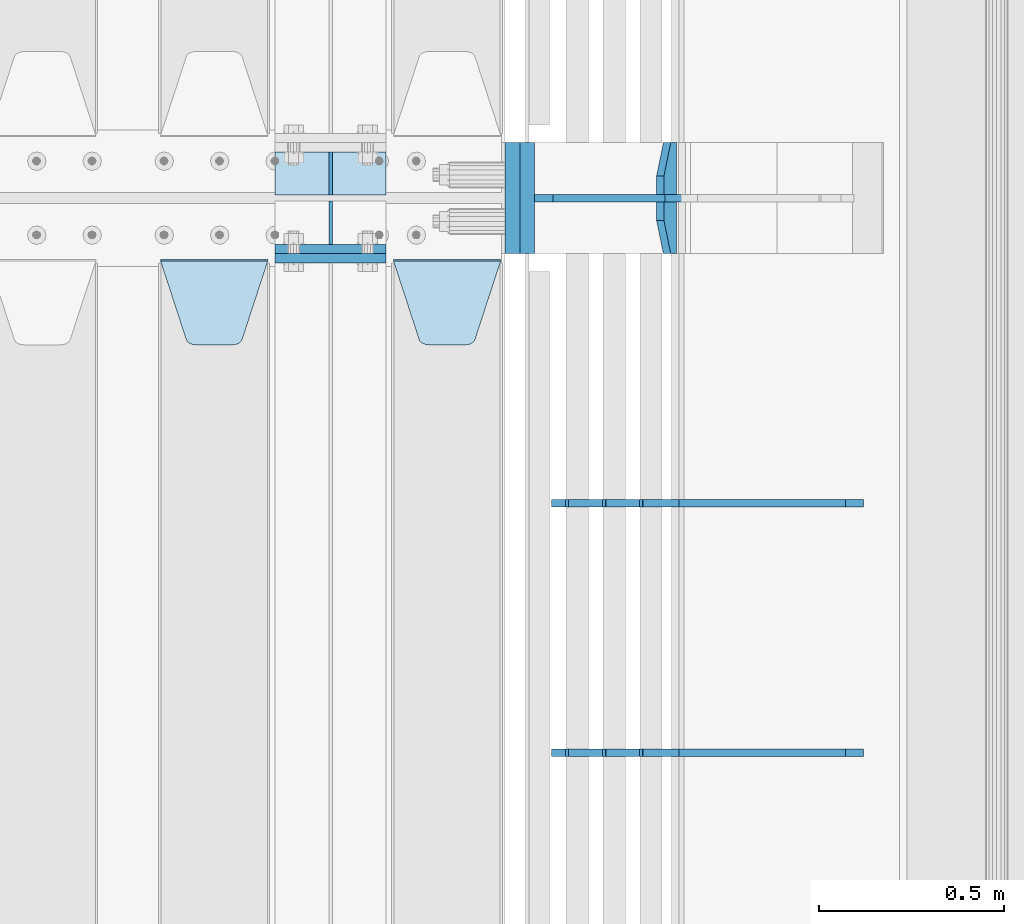
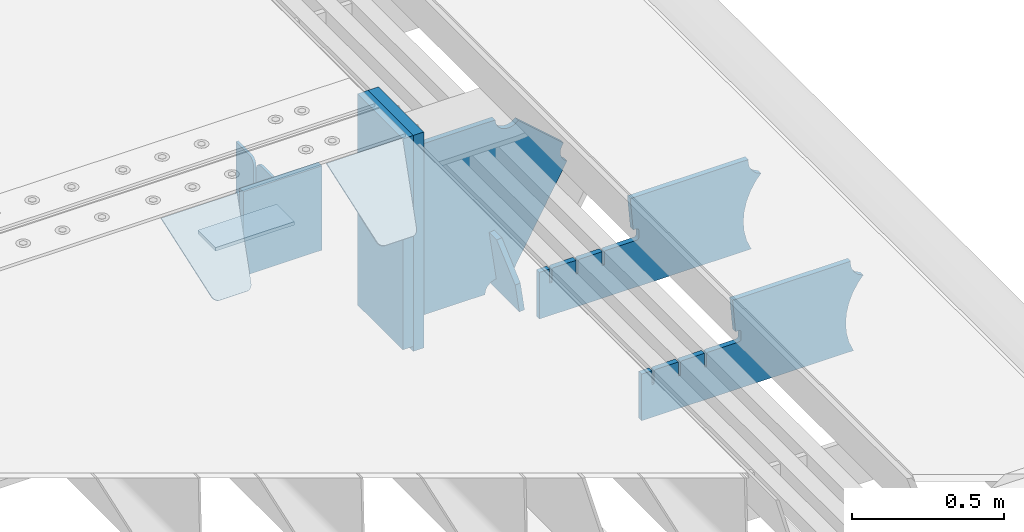
# One storey, part 190 of 208: 13 plates.
"""IFC2X3 building model written with IfcOpenShell, lengths in millimetres."""

from ifc_helpers import new_model, si_unit, frame, origin_with_axes, place, context, subcontext, project, spatial, faceted_brep, material, type_object, element, save


model = new_model("IFC2X3")

# Units and contexts
model_context = context("Model", 3, precision=1e-05, world=origin_with_axes())
body_context = subcontext(model_context, "Body", "Model", "MODEL_VIEW")
ifc_project = project(units=[si_unit("LENGTHUNIT", "METRE", prefix="MILLI"), si_unit("AREAUNIT", "SQUARE_METRE"), si_unit("VOLUMEUNIT", "CUBIC_METRE"), si_unit("MASSUNIT", "GRAM", prefix="KILO"), si_unit("TIMEUNIT", "SECOND"), si_unit("PLANEANGLEUNIT", "RADIAN"), si_unit("SOLIDANGLEUNIT", "STERADIAN"), si_unit("THERMODYNAMICTEMPERATUREUNIT", "DEGREE_CELSIUS"), si_unit("LUMINOUSINTENSITYUNIT", "LUMEN")], contexts=[model_context])

# Site, building, storey
site_placement = place(None, origin_with_axes())
site = spatial("IfcSite", under=ifc_project, at=site_placement, CompositionType="ELEMENT")
building_placement = place(site_placement, origin_with_axes())
building = spatial("IfcBuilding", under=site, at=building_placement, Name="Standard", CompositionType="ELEMENT")
storey_placement = place(building_placement, origin_with_axes())
storey = spatial("IfcBuildingStorey", under=building, at=storey_placement, Name="Undefined", CompositionType="ELEMENT", Elevation=0.0)

# Plates
ifc_material_1 = material(Name="STEEL/S355N")
plate_type_1 = type_object("IfcPlateType", PredefinedType="NOTDEFINED")
plate_1_placement = place(storey_placement, frame((-26255.0, 2862.49999999999, -339.999999999993), z_axis=(0.0, 0.0, 1.0), x_axis=(1.0, 0.0, 0.0)))
element("IfcPlate", 1, at=plate_1_placement, inside=storey, type_object=plate_type_1, material=ifc_material_1, context=body_context, shape_type="Brep", body=[
    faceted_brep([(0.0, -12.5, 0.0), (0.0, -12.5, 310.0), (0.0, 12.5, 310.0), (0.0, 12.5, 0.0), (300.0, -12.5, 310.0), (300.0, 12.5, 310.0), (300.0, -12.5, 0.0), (300.0, 12.5, 0.0)], [[[0, 1, 2, 3]], [[1, 4, 5, 2]], [[4, 6, 7, 5]], [[6, 0, 3, 7]], [[5, 7, 3, 2]], [[6, 4, 1, 0]]]),
])
plate_2_placement = place(storey_placement, frame((-26255.0, 2837.5, -340.000000000044), z_axis=(0.0, 0.0, 1.0), x_axis=(1.0, 0.0, 0.0)))
element("IfcPlate", 2, at=plate_2_placement, inside=storey, type_object=plate_type_1, material=ifc_material_1, context=body_context, shape_type="Brep", body=[
    faceted_brep([(0.0, -12.5, 0.0), (0.0, -12.5, 340.0), (0.0, 12.5, 340.0), (0.0, 12.5, 0.0), (300.0, -12.5, 340.0), (300.0, 12.5, 340.0), (300.0, -12.5, 0.0), (300.0, 12.5, 0.0)], [[[0, 1, 2, 3]], [[1, 4, 5, 2]], [[4, 6, 7, 5]], [[6, 0, 3, 7]], [[5, 7, 3, 2]], [[6, 4, 1, 0]]]),
])
plate_type_2 = type_object("IfcPlateType", PredefinedType="NOTDEFINED")
plate_3_placement = place(storey_placement, frame((-26255.0, 3007.99999999999, -342.999999999993), z_axis=(0.0, 1.0, 0.0), x_axis=(1.0, 0.0, 0.0)))
element("IfcPlate", 3, at=plate_3_placement, inside=storey, type_object=plate_type_2, material=ifc_material_1, context=body_context, shape_type="Brep", body=[
    faceted_brep([(0.0, -7.0, 0.0), (0.0, -7.0, 117.0), (0.0, 7.0, 117.0), (0.0, 7.0, 0.0), (300.0, -7.0, 117.0), (300.0, 7.0, 117.0), (300.0, -7.0, 0.0), (300.0, 7.0, 0.0)], [[[0, 1, 2, 3]], [[1, 4, 5, 2]], [[4, 6, 7, 5]], [[6, 0, 3, 7]], [[5, 7, 3, 2]], [[6, 4, 1, 0]]]),
])
plate_type_3 = type_object("IfcPlateType", PredefinedType="NOTDEFINED")
for number, where, z_axis, x_axis in (
    (4, (-26105.0, 3007.99999999999, -29.999999999993), (0.0, 0.0, -1.0), (0.0, 1.0, 0.0)),
    (5, (-26105.0, 2991.99999999999, -29.999999999993), (0.0, 0.0, -1.0), (0.0, -1.0, 0.0)),
):
    element("IfcPlate", number, at=place(storey_placement, frame(where, z_axis=z_axis, x_axis=x_axis)), inside=storey, type_object=plate_type_3, material=ifc_material_1, context=body_context, shape_type="Brep", body=[
        faceted_brep([(0.0, -5.0, 30.0), (0.0, -5.0, 306.0), (0.0, 5.0, 306.0), (0.0, 5.0, 30.0), (117.0, -5.0, 306.0), (117.0, 5.0, 306.0), (117.0, -5.0, 0.0), (117.0, 5.0, 0.0), (30.0, -5.0, 0.0), (30.0, 5.0, 0.0), (24.7905546699922, -5.0, 0.455767409633758), (24.7905546699922, 5.0, 0.455767409633758), (19.7393957002296, -5.0, 1.80922137642275), (19.7393957002296, 5.0, 1.80922137642275), (15.0, -5.0, 4.01923788646684), (15.0, 5.0, 4.01923788646684), (10.7163717094036, -5.0, 7.01866670643066), (10.7163717094036, 5.0, 7.01866670643066), (7.01866670643085, -5.0, 10.7163717094038), (7.01866670643085, 5.0, 10.7163717094038), (4.01923788646673, -5.0, 15.0), (4.01923788646673, 5.0, 15.0), (1.80922137642301, -5.0, 19.7393957002299), (1.80922137642301, 5.0, 19.7393957002299), (0.455767409634063, -5.0, 24.7905546699921), (0.455767409634063, 5.0, 24.7905546699921)], [[[0, 1, 2, 3]], [[1, 4, 5, 2]], [[4, 6, 7, 5]], [[6, 8, 9, 7]], [[8, 10, 11, 9]], [[10, 12, 13, 11]], [[12, 14, 15, 13]], [[14, 16, 17, 15]], [[16, 18, 19, 17]], [[18, 20, 21, 19]], [[20, 22, 23, 21]], [[22, 24, 25, 23]], [[24, 0, 3, 25]], [[5, 7, 9, 11, 13, 15, 17, 19, 21, 23, 25, 3, 2]], [[24, 22, 20, 18, 16, 14, 12, 10, 8, 6, 4, 1, 0]]]),
    ])
plate_type_4 = type_object("IfcPlateType", PredefinedType="NOTDEFINED")
plate_4_placement = place(storey_placement, frame((-25935.0, 2831.76776695596, -1.76776695296758), z_axis=(0.0, -0.707106781186548, -0.707106781186547), x_axis=(1.0, 0.0, 0.0)))
element("IfcPlate", 6, at=plate_4_placement, inside=storey, type_object=plate_type_4, material=ifc_material_1, context=body_context, shape_type="Brep", body=[
    faceted_brep([(0.0, -2.5, 0.0), (69.345504679477, -2.5, 300.17173142483), (69.345504679477, 2.5, 300.17173142483), (0.0, 2.5, 0.0), (70.9274061199576, -2.5, 304.897442415399), (70.9274061199576, 2.5, 304.8974424154), (73.3818627772307, -2.5, 309.234538108527), (73.3818627772307, 2.5, 309.234538108527), (76.6187032999551, -2.5, 313.023683126103), (76.6187032999551, 2.5, 313.023683126103), (80.5190132704993, -2.5, 316.125672595371), (80.5190132704993, 2.5, 316.125672595371), (84.9395038596849, -2.5, 318.426546230476), (84.9395038596849, 2.50000000000091, 318.426546230476), (89.7177759439219, -2.5, 319.841774983275), (89.7177759439219, 2.50000000000091, 319.841774983275), (94.678286292652, -2.49999999999909, 320.319366455078), (94.678286292652, 2.5, 320.319366455078), (195.321713707348, -2.49999999999909, 320.319366455078), (195.321713707348, 2.5, 320.319366455078), (200.282224056078, -2.5, 319.841774983275), (200.282224056078, 2.5, 319.841774983274), (205.060496140315, -2.5, 318.426546230475), (205.060496140315, 2.5, 318.426546230475), (209.480986729501, -2.5, 316.125672595371), (209.480986729501, 2.50000000000091, 316.125672595371), (213.381296700045, -2.5, 313.023683126102), (213.381296700045, 2.5, 313.023683126102), (216.618137222769, -2.5, 309.234538108526), (216.618137222769, 2.5, 309.234538108527), (219.072593880042, -2.5, 304.897442415399), (219.072593880042, 2.5, 304.897442415399), (220.654495320523, -2.5, 300.17173142483), (220.654495320523, 2.5, 300.17173142483), (290.0, -2.5, 0.0), (290.0, 2.5, 0.0)], [[[0, 1, 2, 3]], [[1, 4, 5, 2]], [[4, 6, 7, 5]], [[6, 8, 9, 7]], [[8, 10, 11, 9]], [[10, 12, 13, 11]], [[12, 14, 15, 13]], [[14, 16, 17, 15]], [[16, 18, 19, 17]], [[18, 20, 21, 19]], [[20, 22, 23, 21]], [[22, 24, 25, 23]], [[24, 26, 27, 25]], [[26, 28, 29, 27]], [[28, 30, 31, 29]], [[30, 32, 33, 31]], [[32, 34, 35, 33]], [[34, 0, 3, 35]], [[5, 7, 9, 11, 13, 15, 17, 19, 21, 23, 25, 27, 29, 31, 33, 35, 3, 2]], [[34, 32, 30, 28, 26, 24, 22, 20, 18, 16, 14, 12, 10, 8, 6, 4, 1, 0]]]),
])
plate_5_placement = place(storey_placement, frame((-26565.0, 2831.76776695596, -1.76776695296758), z_axis=(0.0, -0.707106781186548, -0.707106781186547), x_axis=(1.0, 0.0, 0.0)))
element("IfcPlate", 7, at=plate_5_placement, inside=storey, type_object=plate_type_4, material=ifc_material_1, context=body_context, shape_type="Brep", body=[
    faceted_brep([(0.0, -2.5, 0.0), (69.345504679477, -2.5, 300.17173142483), (69.345504679477, 2.5, 300.17173142483), (0.0, 2.5, 0.0), (70.9274061199576, -2.5, 304.897442415399), (70.9274061199576, 2.5, 304.8974424154), (73.3818627772307, -2.5, 309.234538108527), (73.3818627772307, 2.5, 309.234538108527), (76.6187032999551, -2.5, 313.023683126103), (76.6187032999551, 2.5, 313.023683126103), (80.5190132704993, -2.5, 316.125672595371), (80.5190132704993, 2.5, 316.125672595371), (84.9395038596849, -2.5, 318.426546230476), (84.9395038596849, 2.50000000000091, 318.426546230476), (89.7177759439219, -2.5, 319.841774983275), (89.7177759439219, 2.50000000000091, 319.841774983275), (94.678286292652, -2.49999999999909, 320.319366455078), (94.678286292652, 2.5, 320.319366455078), (195.321713707348, -2.49999999999909, 320.319366455078), (195.321713707348, 2.5, 320.319366455078), (200.282224056078, -2.5, 319.841774983275), (200.282224056078, 2.5, 319.841774983274), (205.060496140315, -2.5, 318.426546230475), (205.060496140315, 2.5, 318.426546230475), (209.480986729501, -2.5, 316.125672595371), (209.480986729501, 2.50000000000091, 316.125672595371), (213.381296700045, -2.5, 313.023683126102), (213.381296700045, 2.5, 313.023683126102), (216.618137222769, -2.5, 309.234538108526), (216.618137222769, 2.5, 309.234538108527), (219.072593880042, -2.5, 304.897442415399), (219.072593880042, 2.5, 304.897442415399), (220.654495320523, -2.5, 300.17173142483), (220.654495320523, 2.5, 300.17173142483), (290.0, -2.5, 0.0), (290.0, 2.5, 0.0)], [[[0, 1, 2, 3]], [[1, 4, 5, 2]], [[4, 6, 7, 5]], [[6, 8, 9, 7]], [[8, 10, 11, 9]], [[10, 12, 13, 11]], [[12, 14, 15, 13]], [[14, 16, 17, 15]], [[16, 18, 19, 17]], [[18, 20, 21, 19]], [[20, 22, 23, 21]], [[22, 24, 25, 23]], [[24, 26, 27, 25]], [[26, 28, 29, 27]], [[28, 30, 31, 29]], [[30, 32, 33, 31]], [[32, 34, 35, 33]], [[34, 0, 3, 35]], [[5, 7, 9, 11, 13, 15, 17, 19, 21, 23, 25, 27, 29, 31, 33, 35, 3, 2]], [[34, 32, 30, 28, 26, 24, 22, 20, 18, 16, 14, 12, 10, 8, 6, 4, 1, 0]]]),
])
plate_type_5 = type_object("IfcPlateType", PredefinedType="NOTDEFINED")
plate_6_placement = place(storey_placement, frame((-25178.9224668054, 3150.00000000169, -871.412303810021), z_axis=(0.0, -1.0, 0.0), x_axis=(-0.137902988002446, 0.0, 0.990445741017648)))
element("IfcPlate", 8, at=plate_6_placement, inside=storey, type_object=plate_type_5, material=ifc_material_1, context=body_context, shape_type="Brep", body=[
    faceted_brep([(0.0, -10.0, 0.0), (-1.98269844986498e-10, -10.0, 300.0), (-1.98269844986498e-10, 10.0000000000036, 300.0), (0.0, 10.0, 0.0), (115.0, -9.99999999999636, 300.0), (115.0, 10.0, 300.0), (250.0, -9.99999999999636, 210.0), (250.0, 10.0, 210.0), (250.0, -9.99999999999636, 90.0), (250.0, 10.0, 90.0), (115.0, -9.99999999999636, -1.10503606265411e-10), (115.0, 10.0, -1.10503606265411e-10)], [[[0, 1, 2, 3]], [[1, 4, 5, 2]], [[4, 6, 7, 5]], [[6, 8, 9, 7]], [[8, 10, 11, 9]], [[10, 0, 3, 11]], [[5, 7, 9, 11, 3, 2]], [[10, 8, 6, 4, 1, 0]]]),
])
ifc_material_2 = material()
plate_type_6 = type_object("IfcPlateType", PredefinedType="NOTDEFINED")
plate_7_placement = place(storey_placement, frame((-25573.0011701094, 3150.0, -889.999999999995), z_axis=(0.0, 0.0, 1.0), x_axis=(0.0, -1.0, 0.0)))
element("IfcPlate", 9, at=plate_7_placement, inside=storey, type_object=plate_type_6, material=ifc_material_2, context=body_context, shape_type="Brep", body=[
    faceted_brep([(0.0, -20.0, 0.0), (0.0, -20.0, 870.0), (0.0, 20.0, 870.0), (0.0, 20.0, 0.0), (300.0, -20.0, 870.0), (300.0, 20.0, 870.0), (300.0, -20.0, 3.63797880709171e-12), (300.0, 20.0, 3.63797880709171e-12)], [[[0, 1, 2, 3]], [[1, 4, 5, 2]], [[4, 6, 7, 5]], [[6, 0, 3, 7]], [[5, 7, 3, 2]], [[6, 4, 1, 0]]]),
])
plate_8_placement = place(storey_placement, frame((-25613.0, 3150.0, -870.0), z_axis=(0.0, 0.0, 1.0), x_axis=(0.0, -1.0, 0.0)))
element("IfcPlate", 10, at=plate_8_placement, inside=storey, type_object=plate_type_6, material=ifc_material_2, context=body_context, shape_type="Brep", body=[
    faceted_brep([(0.0, -20.0, 0.0), (9.5367431640625e-07, -20.0, 850.0), (9.5367431640625e-07, 20.0, 850.0), (0.0, 20.0, 0.0), (300.0, -20.0, 850.0), (300.0, 20.0, 850.0), (300.0, -20.0, 3.63797880709171e-12), (300.0, 20.0, 3.63797880709171e-12)], [[[0, 1, 2, 3]], [[1, 4, 5, 2]], [[4, 6, 7, 5]], [[6, 0, 3, 7]], [[5, 7, 3, 2]], [[6, 4, 1, 0]]]),
])
plate_type_7 = type_object("IfcPlateType", PredefinedType="NOTDEFINED")
plate_9_placement = place(storey_placement, frame((-24667.0817660324, 1499.99928283691, -374.002067436517), z_axis=(0.0, 0.0, 1.0), x_axis=(-1.0, 0.0, 0.0)))
element("IfcPlate", 11, at=plate_9_placement, inside=storey, type_object=plate_type_7, material=ifc_material_1, context=body_context, shape_type="Brep", body=[
    faceted_brep([(801.919404066546, -10.0, 188.0), (801.919404066546, 10.0, 188.0), (801.919404066546, 10.0000000000001, 132.002067436952), (801.919404066546, -10.0, 132.002067436952), (793.919404066546, 10.0000000000001, 132.002067436952), (793.919404066546, -10.0, 132.002067436952), (793.919404066546, 10.0000000000001, 180.002067436952), (793.919404066546, -10.0, 180.002067436952), (793.527856196906, 10.0000000000001, 182.474203391951), (793.527856196906, -10.0, 182.474203391951), (792.391540021545, 10.0000000000001, 184.704349455291), (792.391540021545, -10.0, 184.704349455291), (790.621686084887, 10.0000000000001, 186.474203391951), (790.621686084887, -10.0, 186.474203391951), (788.391540021545, 10.0000000000001, 187.610519567313), (788.391540021545, -10.0, 187.610519567313), (785.919404066546, -10.0, 188.002067436952), (785.919404066546, 10.0, 188.0), (841.0, -10.0, 188.0), (841.0, -10.0, 0.0), (841.0, 10.0, 0.0), (841.0, 10.0, 188.0), (33.3619566735979, -10.0, 0.0), (33.3619566735979, 10.0, 0.0), (36.2350612208174, -10.0, 4.68848050267007), (36.2350612208174, 10.0, 4.68848050267007), (51.4877592159428, -10.0, 41.5117508652783), (51.4877592159428, 10.0, 41.5117508652783), (60.792242588137, -10.0, 80.2677133162963), (60.792242588137, 10.0, 80.2677133162963), (63.9194040769726, -10.0, 120.002067436515), (63.9194040769726, 10.0, 120.002067436515), (60.792242588137, -10.0, 159.736421556734), (60.792242588137, 10.0, 159.736421556734), (51.4877592159428, -10.0, 198.492384007752), (51.4877592159428, 10.0, 198.492384007752), (36.2350612208174, -10.0, 235.31565437036), (36.2350612208174, 10.0, 235.31565437036), (15.4097206482074, -10.0, 269.299521518803), (15.4097206482074, 10.0, 269.299521518803), (-3.35474438098754, -10.0, 291.269887256574), (-3.35474438098754, 10.0, 291.269887256574), (-2.36881039375294, -10.0, 291.426043859339), (-2.36881039375294, 10.0, 291.426043859339), (17.1449676604716, -10.0, 301.368810393754), (17.1449676604716, 10.0, 301.368810393754), (32.6311896062471, -10.0, 316.855032339527), (32.6311896062471, 10.0, 316.855032339527), (42.573956140659, -10.0, 336.368810393754), (42.573956140659, 10.0, 336.368810393754), (46.0, -10.0, 358.0), (46.0, 10.0, 358.0), (45.0495205499174, -10.0, 364.001091067617), (45.0495205499174, 10.0, 364.001091067617), (495.040008544922, -10.0, 364.010009765625), (495.040008544922, 10.0, 364.010009765625), (483.600036621094, -10.0, 233.759994506836), (483.600036621094, 10.0, 233.759994506836), (472.0, -10.0, 233.759994506836), (472.0, 10.0, 233.759994506836), (468.909830056251, -10.0, 233.270559669787), (468.909830056251, 10.0, 233.270559669787), (466.122147477075, -10.0, 231.850164450585), (466.122147477075, 10.0, 231.850164450585), (463.909830056251, -10.0, 229.637847029761), (463.909830056251, 10.0, 229.637847029761), (462.489434837047, -10.0, 226.850164450585), (462.489434837047, 10.0, 226.850164450585), (462.0, -10.0, 223.759994506836), (462.0, 10.0, 223.759994506836), (462.0, -10.0, 198.0), (462.0, 10.0, 198.0), (462.489434837047, -10.0, 194.909830056251), (462.489434837047, 10.0, 194.909830056251), (463.909830056251, -10.0, 192.122147477075), (463.909830056251, 10.0, 192.122147477075), (466.122147477075, -10.0, 189.909830056251), (466.122147477075, 10.0, 189.909830056251), (468.909830056251, -10.0, 188.489434837048), (468.909830056251, 10.0, 188.489434837048), (472.0, -10.0, 188.0), (472.0, 10.0, 188.0), (585.919404066546, -10.0, 188.002067436952), (585.919404066546, 10.0, 188.0), (588.391540021545, -10.0, 187.610519567313), (588.391540021545, 10.0, 187.610519567313), (590.621686084887, -10.0, 186.474203391951), (590.621686084887, 10.0, 186.474203391951), (592.391540021545, -10.0, 184.704349455291), (592.391540021545, 10.0, 184.704349455291), (593.527856196906, -10.0, 182.474203391951), (593.527856196906, 10.0, 182.474203391951), (593.919404066546, -10.0, 180.002067436952), (593.919404066546, 10.0, 180.002067436952), (593.919404066546, -10.0, 132.002067436952), (593.919404066546, 10.0, 132.002067436952), (601.919404066546, -10.0, 132.002067436952), (601.919404066546, 10.0, 132.002067436952), (601.919404066546, -10.0, 188.0), (601.919404066546, 10.0, 188.0), (685.919404066546, -10.0, 188.002067436952), (685.919404066546, 10.0, 188.0), (688.391540021545, -10.0, 187.610519567313), (688.391540021545, 10.0, 187.610519567313), (690.621686084887, -10.0, 186.474203391951), (690.621686084887, 10.0, 186.474203391951), (692.391540021545, -10.0, 184.704349455291), (692.391540021545, 10.0, 184.704349455291), (693.527856196906, -10.0, 182.474203391951), (693.527856196906, 10.0, 182.474203391951), (693.919404066546, -10.0, 180.002067436952), (693.919404066546, 10.0, 180.002067436952), (693.919404066546, -10.0, 132.002067436952), (693.919404066546, 9.99999999999989, 132.002067436952), (701.919404066546, -10.0, 132.002067436952), (701.919404066546, 9.99999999999989, 132.002067436952), (701.919404066546, -10.0, 188.0), (701.919404066546, 10.0, 188.0)], [[[0, 1, 2, 3]], [[3, 2, 4, 5]], [[5, 4, 6, 7]], [[7, 6, 8, 9]], [[9, 8, 10, 11]], [[11, 10, 12, 13]], [[13, 12, 14, 15]], [[16, 15, 14, 17]], [[18, 19, 20, 21]], [[20, 19, 22, 23]], [[22, 24, 25, 23]], [[26, 27, 25, 24]], [[28, 29, 27, 26]], [[30, 31, 29, 28]], [[32, 33, 31, 30]], [[34, 35, 33, 32]], [[36, 37, 35, 34]], [[38, 39, 37, 36]], [[39, 38, 40, 41]], [[40, 42, 43, 41]], [[44, 45, 43, 42]], [[46, 47, 45, 44]], [[48, 49, 47, 46]], [[50, 51, 49, 48]], [[52, 53, 51, 50]], [[54, 55, 53, 52]], [[54, 56, 57, 55]], [[56, 58, 59, 57]], [[58, 60, 61, 59]], [[60, 62, 63, 61]], [[62, 64, 65, 63]], [[64, 66, 67, 65]], [[66, 68, 69, 67]], [[68, 70, 71, 69]], [[70, 72, 73, 71]], [[72, 74, 75, 73]], [[74, 76, 77, 75]], [[76, 78, 79, 77]], [[78, 80, 81, 79]], [[81, 80, 82, 83]], [[82, 84, 85, 83]], [[86, 87, 85, 84]], [[88, 89, 87, 86]], [[90, 91, 89, 88]], [[92, 93, 91, 90]], [[94, 95, 93, 92]], [[96, 97, 95, 94]], [[98, 99, 97, 96]], [[99, 98, 100, 101]], [[100, 102, 103, 101]], [[104, 105, 103, 102]], [[106, 107, 105, 104]], [[108, 109, 107, 106]], [[110, 111, 109, 108]], [[112, 113, 111, 110]], [[114, 115, 113, 112]], [[116, 117, 115, 114]], [[117, 116, 16, 17]], [[12, 10, 8, 6, 4, 2, 1, 21, 20, 23, 25, 27, 29, 31, 33, 35, 37, 39, 41, 43, 45, 47, 49, 51, 53, 55, 57, 59, 61, 63, 65, 67, 69, 71, 73, 75, 77, 79, 81, 83, 85, 87, 89, 91, 93, 95, 97, 99, 101, 103, 105, 107, 109, 111, 113, 115, 117, 17, 14]], [[18, 21, 1, 0]], [[116, 114, 112, 110, 108, 106, 104, 102, 100, 98, 96, 94, 92, 90, 88, 86, 84, 82, 80, 78, 76, 74, 72, 70, 68, 66, 64, 62, 60, 58, 56, 54, 52, 50, 48, 46, 44, 42, 40, 38, 36, 34, 32, 30, 28, 26, 24, 22, 19, 18, 0, 3, 5, 7, 9, 11, 13, 15, 16]]]),
])
plate_10_placement = place(storey_placement, frame((-24667.0817660324, 2174.99928283691, -374.002067436516), z_axis=(0.0, 0.0, 1.0), x_axis=(-1.0, 0.0, 0.0)))
element("IfcPlate", 12, at=plate_10_placement, inside=storey, type_object=plate_type_7, material=ifc_material_1, context=body_context, shape_type="Brep", body=[
    faceted_brep([(801.919404066546, -10.0, 188.0), (801.919404066546, 10.0, 188.0), (801.919404066546, 10.0000000000001, 132.002067436952), (801.919404066546, -10.0, 132.002067436952), (793.919404066546, 10.0000000000001, 132.002067436952), (793.919404066546, -10.0, 132.002067436952), (793.919404066546, 10.0000000000001, 180.002067436952), (793.919404066546, -10.0, 180.002067436952), (793.527856196906, 10.0000000000001, 182.474203391951), (793.527856196906, -10.0, 182.474203391951), (792.391540021545, 10.0000000000001, 184.704349455291), (792.391540021545, -10.0, 184.704349455291), (790.621686084887, 10.0000000000001, 186.474203391951), (790.621686084887, -10.0, 186.474203391951), (788.391540021545, 10.0000000000001, 187.610519567313), (788.391540021545, -10.0, 187.610519567313), (785.919404066546, -10.0, 188.002067436952), (785.919404066546, 10.0, 188.0), (841.0, -10.0, 188.0), (841.0, -10.0, 0.0), (841.0, 10.0, 0.0), (841.0, 10.0, 188.0), (33.3619566735979, -10.0, 0.0), (33.3619566735979, 10.0, 0.0), (36.2350612208174, -10.0, 4.68848050267007), (36.2350612208174, 10.0, 4.68848050267007), (51.4877592159428, -10.0, 41.5117508652783), (51.4877592159428, 10.0, 41.5117508652783), (60.792242588137, -10.0, 80.2677133162963), (60.792242588137, 10.0, 80.2677133162963), (63.9194040769726, -10.0, 120.002067436515), (63.9194040769726, 10.0, 120.002067436515), (60.792242588137, -10.0, 159.736421556734), (60.792242588137, 10.0, 159.736421556734), (51.4877592159428, -10.0, 198.492384007752), (51.4877592159428, 10.0, 198.492384007752), (36.2350612208174, -10.0, 235.31565437036), (36.2350612208174, 10.0, 235.31565437036), (15.4097206482074, -10.0, 269.299521518803), (15.4097206482074, 10.0, 269.299521518803), (-3.35474438098754, -10.0, 291.269887256574), (-3.35474438098754, 10.0, 291.269887256574), (-2.36881039375294, -10.0, 291.426043859339), (-2.36881039375294, 10.0, 291.426043859339), (17.1449676604716, -10.0, 301.368810393754), (17.1449676604716, 10.0, 301.368810393754), (32.6311896062471, -10.0, 316.855032339527), (32.6311896062471, 10.0, 316.855032339527), (42.573956140659, -10.0, 336.368810393754), (42.573956140659, 10.0, 336.368810393754), (46.0, -10.0, 358.0), (46.0, 10.0, 358.0), (45.0495205499174, -10.0, 364.001091067617), (45.0495205499174, 10.0, 364.001091067617), (495.040008544922, -10.0, 364.010009765625), (495.040008544922, 10.0, 364.010009765625), (483.600036621094, -10.0, 233.759994506836), (483.600036621094, 10.0, 233.759994506836), (472.0, -10.0, 233.759994506836), (472.0, 10.0, 233.759994506836), (468.909830056251, -10.0, 233.270559669787), (468.909830056251, 10.0, 233.270559669787), (466.122147477075, -10.0, 231.850164450585), (466.122147477075, 10.0, 231.850164450585), (463.909830056251, -10.0, 229.637847029761), (463.909830056251, 10.0, 229.637847029761), (462.489434837047, -10.0, 226.850164450585), (462.489434837047, 10.0, 226.850164450585), (462.0, -10.0, 223.759994506836), (462.0, 10.0, 223.759994506836), (462.0, -10.0, 198.0), (462.0, 10.0, 198.0), (462.489434837047, -10.0, 194.909830056251), (462.489434837047, 10.0, 194.909830056251), (463.909830056251, -10.0, 192.122147477075), (463.909830056251, 10.0, 192.122147477075), (466.122147477075, -10.0, 189.909830056251), (466.122147477075, 10.0, 189.909830056251), (468.909830056251, -10.0, 188.489434837048), (468.909830056251, 10.0, 188.489434837048), (472.0, -10.0, 188.0), (472.0, 10.0, 188.0), (585.919404066546, -10.0, 188.002067436952), (585.919404066546, 10.0, 188.0), (588.391540021545, -10.0, 187.610519567313), (588.391540021545, 10.0, 187.610519567313), (590.621686084887, -10.0, 186.474203391951), (590.621686084887, 10.0, 186.474203391951), (592.391540021545, -10.0, 184.704349455291), (592.391540021545, 10.0, 184.704349455291), (593.527856196906, -10.0, 182.474203391951), (593.527856196906, 10.0, 182.474203391951), (593.919404066546, -10.0, 180.002067436952), (593.919404066546, 10.0, 180.002067436952), (593.919404066546, -10.0, 132.002067436952), (593.919404066546, 10.0, 132.002067436952), (601.919404066546, -10.0, 132.002067436952), (601.919404066546, 10.0, 132.002067436952), (601.919404066546, -10.0, 188.0), (601.919404066546, 10.0, 188.0), (685.919404066546, -10.0, 188.002067436952), (685.919404066546, 10.0, 188.0), (688.391540021545, -10.0, 187.610519567313), (688.391540021545, 10.0, 187.610519567313), (690.621686084887, -10.0, 186.474203391951), (690.621686084887, 10.0, 186.474203391951), (692.391540021545, -10.0, 184.704349455291), (692.391540021545, 10.0, 184.704349455291), (693.527856196906, -10.0, 182.474203391951), (693.527856196906, 10.0, 182.474203391951), (693.919404066546, -10.0, 180.002067436952), (693.919404066546, 10.0, 180.002067436952), (693.919404066546, -10.0, 132.002067436952), (693.919404066546, 9.99999999999989, 132.002067436952), (701.919404066546, -10.0, 132.002067436952), (701.919404066546, 9.99999999999989, 132.002067436952), (701.919404066546, -10.0, 188.0), (701.919404066546, 10.0, 188.0)], [[[0, 1, 2, 3]], [[3, 2, 4, 5]], [[5, 4, 6, 7]], [[7, 6, 8, 9]], [[9, 8, 10, 11]], [[11, 10, 12, 13]], [[13, 12, 14, 15]], [[16, 15, 14, 17]], [[18, 19, 20, 21]], [[20, 19, 22, 23]], [[22, 24, 25, 23]], [[26, 27, 25, 24]], [[28, 29, 27, 26]], [[30, 31, 29, 28]], [[32, 33, 31, 30]], [[34, 35, 33, 32]], [[36, 37, 35, 34]], [[38, 39, 37, 36]], [[39, 38, 40, 41]], [[40, 42, 43, 41]], [[44, 45, 43, 42]], [[46, 47, 45, 44]], [[48, 49, 47, 46]], [[50, 51, 49, 48]], [[52, 53, 51, 50]], [[54, 55, 53, 52]], [[54, 56, 57, 55]], [[56, 58, 59, 57]], [[58, 60, 61, 59]], [[60, 62, 63, 61]], [[62, 64, 65, 63]], [[64, 66, 67, 65]], [[66, 68, 69, 67]], [[68, 70, 71, 69]], [[70, 72, 73, 71]], [[72, 74, 75, 73]], [[74, 76, 77, 75]], [[76, 78, 79, 77]], [[78, 80, 81, 79]], [[81, 80, 82, 83]], [[82, 84, 85, 83]], [[86, 87, 85, 84]], [[88, 89, 87, 86]], [[90, 91, 89, 88]], [[92, 93, 91, 90]], [[94, 95, 93, 92]], [[96, 97, 95, 94]], [[98, 99, 97, 96]], [[99, 98, 100, 101]], [[100, 102, 103, 101]], [[104, 105, 103, 102]], [[106, 107, 105, 104]], [[108, 109, 107, 106]], [[110, 111, 109, 108]], [[112, 113, 111, 110]], [[114, 115, 113, 112]], [[116, 117, 115, 114]], [[117, 116, 16, 17]], [[12, 10, 8, 6, 4, 2, 1, 21, 20, 23, 25, 27, 29, 31, 33, 35, 37, 39, 41, 43, 45, 47, 49, 51, 53, 55, 57, 59, 61, 63, 65, 67, 69, 71, 73, 75, 77, 79, 81, 83, 85, 87, 89, 91, 93, 95, 97, 99, 101, 103, 105, 107, 109, 111, 113, 115, 117, 17, 14]], [[18, 21, 1, 0]], [[116, 114, 112, 110, 108, 106, 104, 102, 100, 98, 96, 94, 92, 90, 88, 86, 84, 82, 80, 78, 76, 74, 72, 70, 68, 66, 64, 62, 60, 58, 56, 54, 52, 50, 48, 46, 44, 42, 40, 38, 36, 34, 32, 30, 28, 26, 24, 22, 19, 18, 0, 3, 5, 7, 9, 11, 13, 15, 16]]]),
])
plate_type_8 = type_object("IfcPlateType", PredefinedType="NOTDEFINED")
plate_11_placement = place(storey_placement, frame((-25150.0011701087, 3000.00000000007, -179.999999999866), z_axis=(0.0, 0.0, -1.0), x_axis=(-1.0, 0.0, 0.0)))
element("IfcPlate", 13, at=plate_11_placement, inside=storey, type_object=plate_type_8, material=ifc_material_1, context=body_context, shape_type="Brep", body=[
    faceted_brep([(46.0258547361482, 10.0, 641.078828352486), (73.3015011074858, 10.0, 445.179898435786), (73.3015011074858, -10.0, 445.179898435786), (46.0258547361482, -10.0, 641.078828352486), (53.4925862871314, 10.0, 442.421838675737), (53.4925862871314, -10.0, 442.421838675737), (25.782050112397, 10.0, 641.444230671289), (25.782050112397, -10.0, 641.444230671289), (54.6652503111618, 10.0, 642.447174185377), (54.6652503111618, -10.0, 642.447174185377), (68.6036632070354, -10.0, 649.549150281387), (68.6036632070354, 10.0, 649.549150281387), (79.6652503111618, -10.0, 660.610737385511), (79.6652503111618, 10.0, 660.610737385511), (86.7672264071698, -10.0, 674.549150281387), (86.7672264071698, 10.0, 674.549150281387), (89.2144005924129, -10.0, 690.0), (89.2144005924129, 10.0, 690.0), (353.0, -10.0, 690.0), (353.0, 10.0, 690.0), (355.447174185243, -10.0, 674.549150281253), (355.447174185243, 10.0, 674.549150281253), (362.549150281251, -10.0, 660.610737385376), (362.549150281251, 10.0, 660.610737385376), (373.610737385377, -10.0, 649.549150281253), (373.610737385377, 10.0, 649.549150281253), (387.549150281251, -10.0, 642.447174185242), (387.549150281251, 10.0, 642.447174185242), (403.0, -10.0, 640.0), (403.0, 10.0, 640.0), (403.0, -10.0, 50.0), (403.0, 10.0, 50.0), (387.549150281251, -10.0, 47.5528258147577), (387.549150281251, 10.0, 47.5528258147577), (373.610737385377, -10.0, 40.4508497187474), (373.610737385377, 10.0, 40.4508497187474), (362.549150281251, -10.0, 29.3892626146236), (362.549150281251, 10.0, 29.3892626146236), (355.447174185243, -10.0, 15.4508497187474), (355.447174185243, 10.0, 15.4508497187474), (353.0, -10.0, 0.0), (353.0, 10.0, 0.0), (50.0, -10.0, 0.0), (50.0, 10.0, 0.0), (47.0349915316328, -10.0, 16.9620037619133), (47.0349915316328, 10.0, 16.9620037619133), (38.4916171352343, -10.0, 31.9123081320451), (38.4916171352343, 10.0, 31.9123081320451), (25.3831239081519, -10.0, 43.0778019479116), (25.3831239081519, 10.0, 43.0778019479116), (9.26418358741648, -10.0, 49.1342538608113), (9.26418358741648, 10.0, 49.1342538608113), (-7.95349204488593, -10.0, 49.363366622344), (-7.95349204488593, 10.0, 49.363366622344), (-24.2278808265401, -10.0, 43.7379673813837), (-24.2278808265401, 10.0, 43.7379673813837), (-37.6288347353438, -10.0, 32.9252303934259), (-37.6288347353438, 10.0, 32.9252303934259), (-210.371165264656, -10.0, 184.074769606574), (-210.371165264656, 10.0, 184.074769606574), (-202.382363280569, -10.0, 196.529747922069), (-202.382363280569, 10.0, 196.529747922069), (-198.388707244045, -10.0, 210.777489969227), (-198.388707244045, 10.0, 210.777489969227), (-198.739957464426, -10.0, 225.570193077959), (-198.739957464426, 10.0, 225.570193077959), (-203.40535180681, -10.0, 239.612327446012), (-203.40535180681, 10.0, 239.612327446012), (-211.976299808361, -10.0, 251.674097313455), (-211.976299808361, 10.0, 251.674097313455), (-223.702166612962, -10.0, 260.699145216992), (-223.702166612962, 10.0, 260.699145216992), (-9.29783338703783, -10.0, 646.300854783008), (-9.29783338703783, 10.0, 646.300854783008), (6.98069453597782, -10.0, 640.647282345602), (6.98069453597782, 10.0, 640.647282345602), (24.2117663163663, -10.0, 640.855891896051), (24.2117663163663, 10.0, 640.855891896051)], [[[0, 1, 2, 3]], [[4, 5, 2, 1]], [[6, 7, 5, 4]], [[8, 9, 10, 11]], [[11, 10, 12, 13]], [[13, 12, 14, 15]], [[15, 14, 16, 17]], [[18, 19, 17, 16]], [[18, 20, 21, 19]], [[20, 22, 23, 21]], [[22, 24, 25, 23]], [[24, 26, 27, 25]], [[26, 28, 29, 27]], [[28, 30, 31, 29]], [[30, 32, 33, 31]], [[32, 34, 35, 33]], [[34, 36, 37, 35]], [[36, 38, 39, 37]], [[38, 40, 41, 39]], [[40, 42, 43, 41]], [[42, 44, 45, 43]], [[44, 46, 47, 45]], [[46, 48, 49, 47]], [[48, 50, 51, 49]], [[50, 52, 53, 51]], [[52, 54, 55, 53]], [[54, 56, 57, 55]], [[56, 58, 59, 57]], [[58, 60, 61, 59]], [[60, 62, 63, 61]], [[62, 64, 65, 63]], [[64, 66, 67, 65]], [[66, 68, 69, 67]], [[68, 70, 71, 69]], [[70, 72, 73, 71]], [[72, 74, 75, 73]], [[74, 76, 77, 75]], [[1, 0, 8, 11, 13, 15, 17, 19, 21, 23, 25, 27, 29, 31, 33, 35, 37, 39, 41, 43, 45, 47, 49, 51, 53, 55, 57, 59, 61, 63, 65, 67, 69, 71, 73, 75, 77, 6, 4]], [[9, 8, 0, 3]], [[76, 74, 72, 70, 68, 66, 64, 62, 60, 58, 56, 54, 52, 50, 48, 46, 44, 42, 40, 38, 36, 34, 32, 30, 28, 26, 24, 22, 20, 18, 16, 14, 12, 10, 9, 3, 2, 5, 7]], [[77, 76, 7, 6]]]),
])

save(model, "model.ifc")
